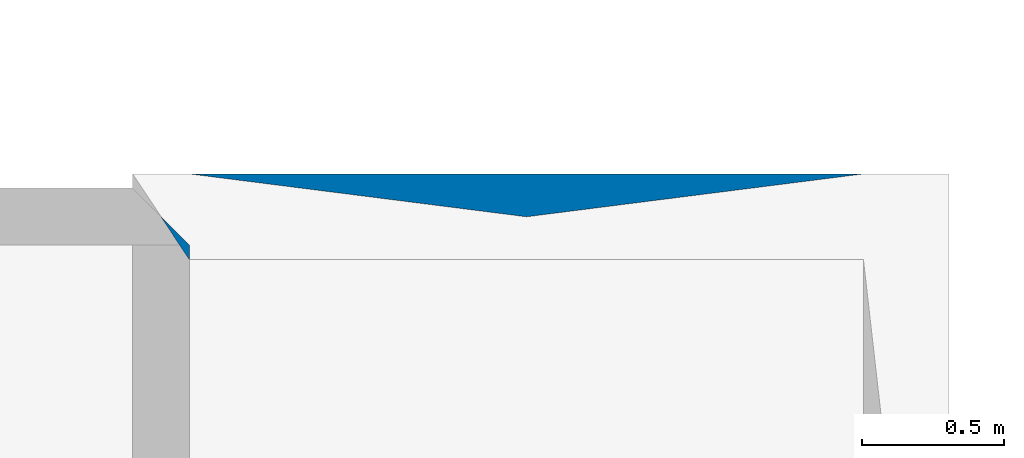
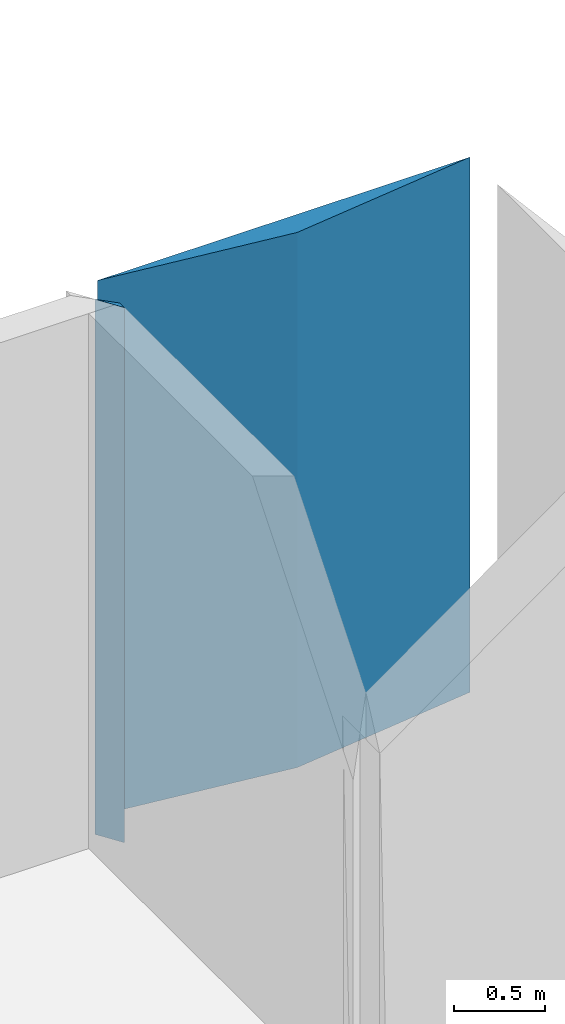
# One storey, part 6 of 72: 2 walls.
"""IFC2X3 building model written with IfcOpenShell, lengths in metres."""

from ifc_helpers import new_model, entity, si_unit, converted_unit, derived_unit, frame, origin_with_axes, place, context, project, spatial, polyline, outline, extrude, material, layer, layer_set, layer_usage, element, save


model = new_model("IFC2X3")

# Units and contexts
context_of_model_1 = context(None, 3, world=origin_with_axes())
context_of_model_2 = context(None, 3, world=origin_with_axes())
context_of_model_3 = context(None, 2, world=origin_with_axes())
context_of_model_4 = context(None, 3, world=origin_with_axes())
ifc_project = project(units=[si_unit("LENGTHUNIT", "METRE"), si_unit("AREAUNIT", "SQUARE_METRE"), si_unit("ELECTRICCURRENTUNIT", "AMPERE"), si_unit("ELECTRICVOLTAGEUNIT", "VOLT"), si_unit("ELECTRICRESISTANCEUNIT", "OHM"), si_unit("POWERUNIT", "WATT"), si_unit("MASSUNIT", "GRAM"), si_unit("SOLIDANGLEUNIT", "STERADIAN"), si_unit("THERMODYNAMICTEMPERATUREUNIT", "KELVIN"), si_unit("PRESSUREUNIT", "PASCAL"), si_unit("LUMINOUSFLUXUNIT", "LUMEN"), si_unit("ILLUMINANCEUNIT", "LUX"), si_unit("FREQUENCYUNIT", "HERTZ"), si_unit("VOLUMEUNIT", "CUBIC_METRE"), si_unit("TIMEUNIT", "SECOND"), derived_unit("VOLUMETRICFLOWRATEUNIT", [(si_unit("TIMEUNIT", "SECOND"), -1), (si_unit("VOLUMEUNIT", "CUBIC_METRE"), 1)]), derived_unit("THERMALTRANSMITTANCEUNIT", [(si_unit("AREAUNIT", "SQUARE_METRE"), -1), (si_unit("THERMODYNAMICTEMPERATUREUNIT", "KELVIN"), -1), (si_unit("POWERUNIT", "WATT"), 1)]), converted_unit("PLANEANGLEUNIT", "DEGREE", entity("IfcPlaneAngleMeasure", 57.29577951308232), si_unit("PLANEANGLEUNIT", "RADIAN"), dimensions=[0, 0, 0, 0, 0, 0, 0])], contexts=[context_of_model_1, context_of_model_2, context_of_model_3, context_of_model_4])

# Site, building, storey
site = spatial("IfcSite", under=ifc_project, CompositionType="ELEMENT")
building_placement = place(None, origin_with_axes())
building = spatial("IfcBuilding", under=site, at=building_placement, Name="200", CompositionType="ELEMENT")
storey_placement = place(building_placement, frame((0.0, 0.0, 15.68000030517578), z_axis=(0.0, 0.0, 1.0), x_axis=(1.0, 0.0, 0.0)))
storey = spatial("IfcBuildingStorey", under=building, at=storey_placement, Name="3.etasje", CompositionType="ELEMENT", Elevation=15.68000030517578)

# Walls
ifc_material_1 = material(Name="Layer-YV04 20 cm")
ifc_layer_1 = layer(ifc_material_1, 0.2000000029802322, ventilated=False)
ifc_layer_set_1 = layer_set([ifc_layer_1])
ifc_layer_usage_1 = layer_usage(ifc_layer_set_1, "AXIS2", "POSITIVE", 0.0)
wall_1_placement = place(storey_placement, frame((3.075984001159668, 52.75015640258789, 0.0), z_axis=(0.0, 0.0, 1.0), x_axis=(-4.371138828673793e-08, 1.0, 0.0)))
element("IfcWallStandardCase", 1, at=wall_1_placement, inside=storey, material=ifc_layer_usage_1, Name="YV04 20 cm", context=context_of_model_1, shape_type="SweptSolid", body=[
    extrude(outline(polyline([(0.0, 0.0), (0.05124282836914067, 4.135903062765138e-25), (0.2512435913085896, 0.200000047683716), (0.3015022277831991, 0.2000000476837159), (0.0, 0.0)])), frame((0.0, 0.0, 0.0), z_axis=(0.0, 0.0, 1.0), x_axis=(0.999999999999999, -4.371139243425936e-08, 0.0)), (0.0, 0.0, 1.0), 3.6),
])
ifc_material_2 = material(Name="Layer-YV04 20 cm")
ifc_layer_2 = layer(ifc_material_2, 0.3015022277832031, ventilated=False)
ifc_layer_set_2 = layer_set([ifc_layer_2])
ifc_layer_usage_2 = layer_usage(ifc_layer_set_2, "AXIS2", "POSITIVE", 0.0)
wall_2_placement = place(storey_placement, frame((5.446785926818848, 52.75015640258789, 0.0), z_axis=(0.0, 0.0, 1.0), x_axis=(-1.0, -8.742277657347586e-08, 0.0)))
element("IfcWallStandardCase", 2, at=wall_2_placement, inside=storey, material=ifc_layer_usage_2, Name="YV04 20 cm", context=context_of_model_1, shape_type="SweptSolid", body=[
    extrude(outline(polyline([(0.0, 0.0), (2.369800806045532, 0.0), (-6.072957894422621e-17, 0.3015022277832043), (2.369800806045533, 0.3015022277832043), (0.0, 0.0)])), frame((0.0, 0.0, 0.0), z_axis=(0.0, 0.0, -1.0), x_axis=(0.9999999999999962, -8.742278219559528e-08, 0.0)), (0.0, 0.0, -1.0), 3.6),
])

save(model, "model.ifc")
